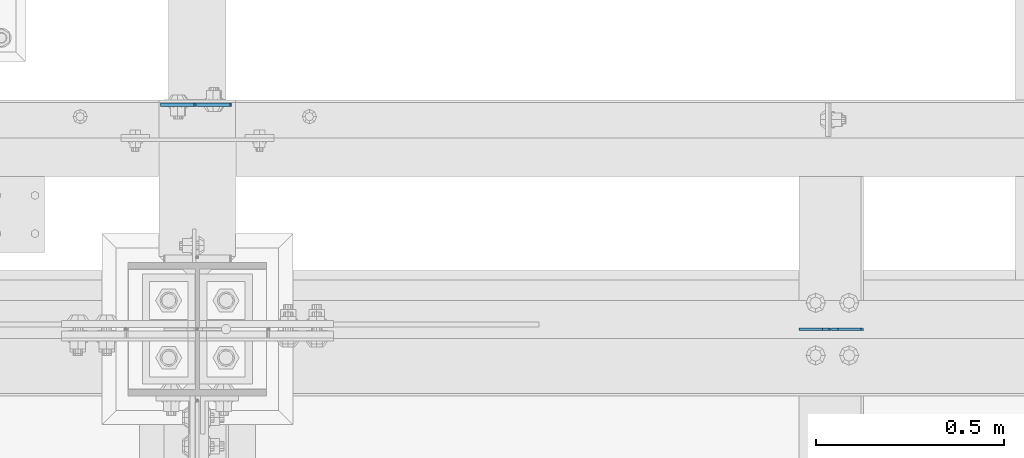
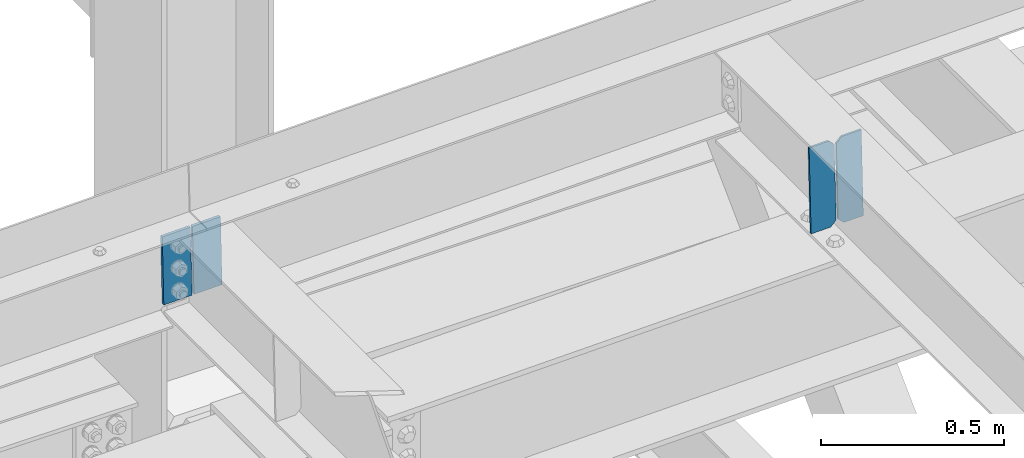
# One storey, part 3509 of 3843: 4 plates, 2 elements without a shape of their own.
"""IFC2X3 building model written with IfcOpenShell, lengths in millimetres."""

from ifc_helpers import new_model, si_unit, frame, origin_with_axes, place, context, subcontext, project, spatial, faceted_brep, material, type_object, element, aggregate, save


model = new_model("IFC2X3")

# Units and contexts
model_context = context("Model", 3, precision=1e-05, world=origin_with_axes())
body_context = subcontext(model_context, "Body", "Model", "MODEL_VIEW")
ifc_project = project(units=[si_unit("LENGTHUNIT", "METRE", prefix="MILLI"), si_unit("AREAUNIT", "SQUARE_METRE"), si_unit("VOLUMEUNIT", "CUBIC_METRE"), si_unit("MASSUNIT", "GRAM", prefix="KILO"), si_unit("TIMEUNIT", "SECOND"), si_unit("PLANEANGLEUNIT", "RADIAN"), si_unit("SOLIDANGLEUNIT", "STERADIAN"), si_unit("THERMODYNAMICTEMPERATUREUNIT", "DEGREE_CELSIUS"), si_unit("LUMINOUSINTENSITYUNIT", "LUMEN")], contexts=[model_context])

# Site, building, storey
site_placement = place(None, origin_with_axes())
site = spatial("IfcSite", under=ifc_project, at=site_placement, CompositionType="ELEMENT")
building_placement = place(site_placement, origin_with_axes())
building = spatial("IfcBuilding", under=site, at=building_placement, Name="Undefined", CompositionType="ELEMENT")
storey_placement = place(building_placement, origin_with_axes())
storey = spatial("IfcBuildingStorey", under=building, at=storey_placement, Name="Undefined", CompositionType="ELEMENT", Elevation=0.0)

# Assembly, plates
assembly_1_placement = place(storey_placement, origin_with_axes())
assembly_1 = element("IfcElementAssembly", 1, at=assembly_1_placement, inside=storey, Name="BEAM", AssemblyPlace="NOTDEFINED", PredefinedType="RIGID_FRAME")
ifc_material = material(Name="STEEL/A572-50")
plate_type_1 = type_object("IfcPlateType", PredefinedType="NOTDEFINED")
plate_1_placement = place(assembly_1_placement, frame((70253.7993980253, 92811.5999974694, 46404.001629281), z_axis=(0.999776270257024, 0.0, 0.0211520550054619), x_axis=(0.0211520550054438, 0.0, -0.999776270257025)))
plate_1 = element("IfcPlate", 2, at=plate_1_placement, type_object=plate_type_1, material=ifc_material, Name="PLATE", context=body_context, shape_type="Brep", body=[
    faceted_brep([(0.0, -4.76249999999709, 0.0), (0.0, -4.76249999999709, 88.9000015258789), (0.0, 4.76249999999709, 88.9000015258789), (0.0, 4.76249999999709, 0.0), (228.600006102781, -4.7625000004191, 88.9000015257589), (228.600006102781, 4.76249999954598, 88.9000015257443), (228.600006103079, -4.7625000004482, 7.27595761418343e-12), (228.600006103079, 4.76249999954598, -7.27595761418343e-12)], [[[0, 1, 2, 3]], [[1, 4, 5, 2]], [[4, 6, 7, 5]], [[6, 0, 3, 7]], [[5, 7, 3, 2]], [[6, 4, 1, 0]]]),
])
plate_2_placement = place(assembly_1_placement, frame((70247.4497695586, 92811.5999980424, 46403.867288449), z_axis=(-0.999776270257024, 0.0, -0.0211520550054595), x_axis=(0.0211520550054438, 0.0, -0.999776270257025)))
plate_2 = element("IfcPlate", 3, at=plate_2_placement, type_object=plate_type_1, material=ifc_material, Name="PLATE", context=body_context, shape_type="Brep", body=[
    faceted_brep([(0.0, -4.76249999999709, 0.0), (0.0, -4.76249999999709, 88.9000015258789), (0.0, 4.76249999999709, 88.9000015258789), (0.0, 4.76249999999709, 0.0), (228.600006102781, -4.7625000004191, 88.9000015257589), (228.600006102781, 4.76249999954598, 88.9000015257443), (228.600006103079, -4.7625000004482, 7.27595761418343e-12), (228.600006103079, 4.76249999954598, -7.27595761418343e-12)], [[[0, 1, 2, 3]], [[1, 4, 5, 2]], [[4, 6, 7, 5]], [[6, 0, 3, 7]], [[5, 7, 3, 2]], [[6, 4, 1, 0]]]),
])
aggregate(assembly_1, [plate_1, plate_2])

assembly_2_placement = place(storey_placement, origin_with_axes())
assembly_2 = element("IfcElementAssembly", 4, at=assembly_2_placement, inside=storey, Name="BEAM", AssemblyPlace="NOTDEFINED", PredefinedType="RIGID_FRAME")
plate_type_2 = type_object("IfcPlateType", PredefinedType="NOTDEFINED")
plate_3_placement = place(assembly_2_placement, frame((72027.7964783455, 92213.8198449631, 46180.7162985209), z_axis=(-0.0211520984278759, 0.00193018200022925, 0.999774406118472), x_axis=(-0.999776269338344, -4.08370000134752e-05, -0.0211520590071558)))
plate_3 = element("IfcPlate", 5, at=plate_3_placement, type_object=plate_type_2, material=ifc_material, Name="STIFFENER", context=body_context, shape_type="Brep", body=[
    faceted_brep([(0.0, -3.17499999999927, 0.0), (6.83940015733242e-10, -3.17499999996653, 288.924999998613), (6.54836185276508e-10, 3.17500000001746, 288.924999998591), (0.0, 3.17499999999927, 0.0), (61.9125003828667, -3.17499999997744, 288.924999998599), (61.9125003828522, 3.17500000002838, 288.924999998584), (79.3750000013097, -3.17499999997744, 271.462500380039), (79.375000001266, 3.17500000002838, 271.462500380017), (79.375000000713, -3.17499999999927, 17.4624996185448), (79.3750000006694, 3.17500000000291, 17.462499618523), (61.9125003821828, -3.17499999999563, -1.45519152283669e-11), (61.9125003821682, 3.17500000000655, -2.91038304567337e-11)], [[[0, 1, 2, 3]], [[1, 4, 5, 2]], [[4, 6, 7, 5]], [[6, 8, 9, 7]], [[8, 10, 11, 9]], [[10, 0, 3, 11]], [[5, 7, 9, 11, 3, 2]], [[10, 8, 6, 4, 1, 0]]]),
])
plate_4_placement = place(assembly_2_placement, frame((71942.0906576552, 92213.8163442516, 46178.9030382992), z_axis=(-0.0211520984278759, 0.00193018200022925, 0.999774406118472), x_axis=(-0.999776269338344, -4.08370000134752e-05, -0.0211520590071558)))
plate_4 = element("IfcPlate", 6, at=plate_4_placement, type_object=plate_type_2, material=ifc_material, Name="STIFFENER", context=body_context, shape_type="Brep", body=[
    faceted_brep([(5.82076609134674e-11, -3.17499999999927, 17.4624996185667), (6.25732354819775e-10, -3.17499999997744, 271.462500380054), (5.82076609134674e-10, 3.17500000002474, 271.462500380039), (0.0, 3.17500000000655, 17.4624996185521), (17.462499619156, -3.17499999997744, 288.924999998606), (17.4624996191269, 3.17500000002474, 288.924999998591), (79.3750000013242, -3.17500000025029, 288.924999998591), (79.3750000013097, 3.1749999997337, 288.92499999857), (79.3750000006548, -3.17500000026484, -2.18278728425503e-11), (79.3750000006403, 3.17499999969732, -2.91038304567337e-11), (17.4624996184866, -3.17500000000291, 7.27595761418343e-12), (17.462499618443, 3.17500000000291, -7.27595761418343e-12)], [[[0, 1, 2, 3]], [[1, 4, 5, 2]], [[4, 6, 7, 5]], [[6, 8, 9, 7]], [[8, 10, 11, 9]], [[10, 0, 3, 11]], [[5, 7, 9, 11, 3, 2]], [[10, 8, 6, 4, 1, 0]]]),
])
aggregate(assembly_2, [plate_3, plate_4])

save(model, "model.ifc")
